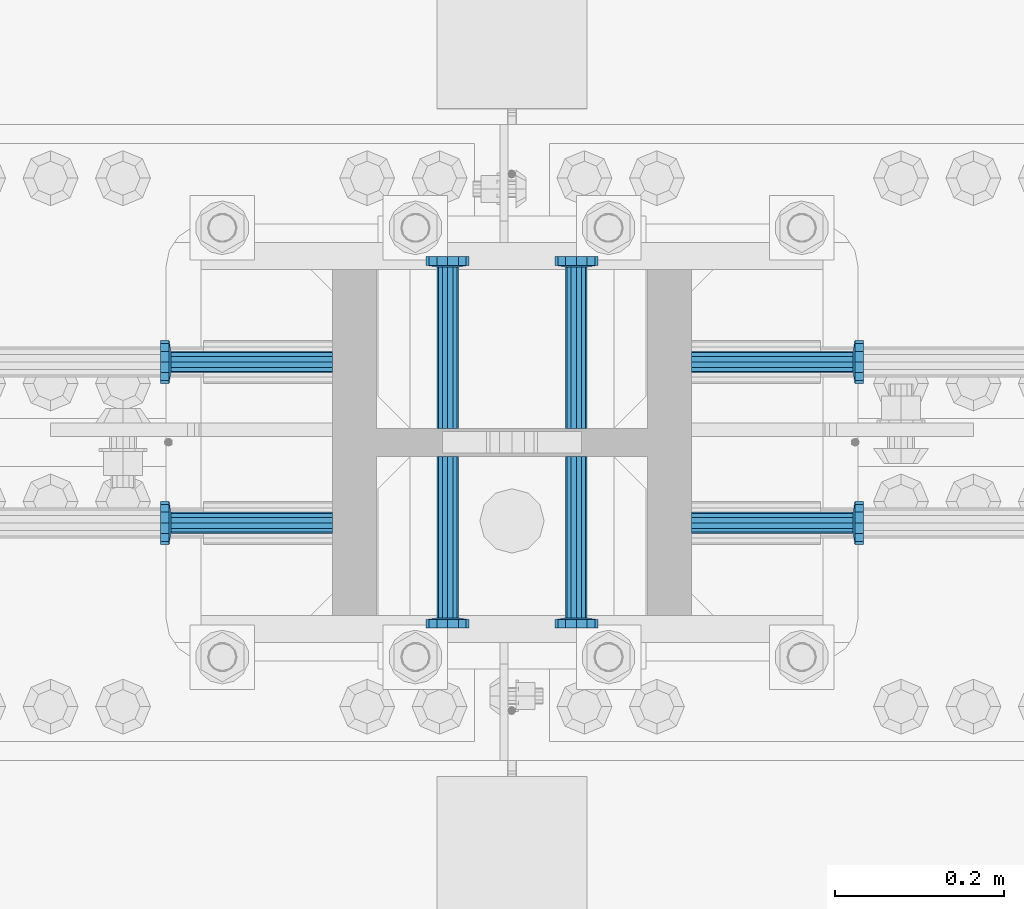
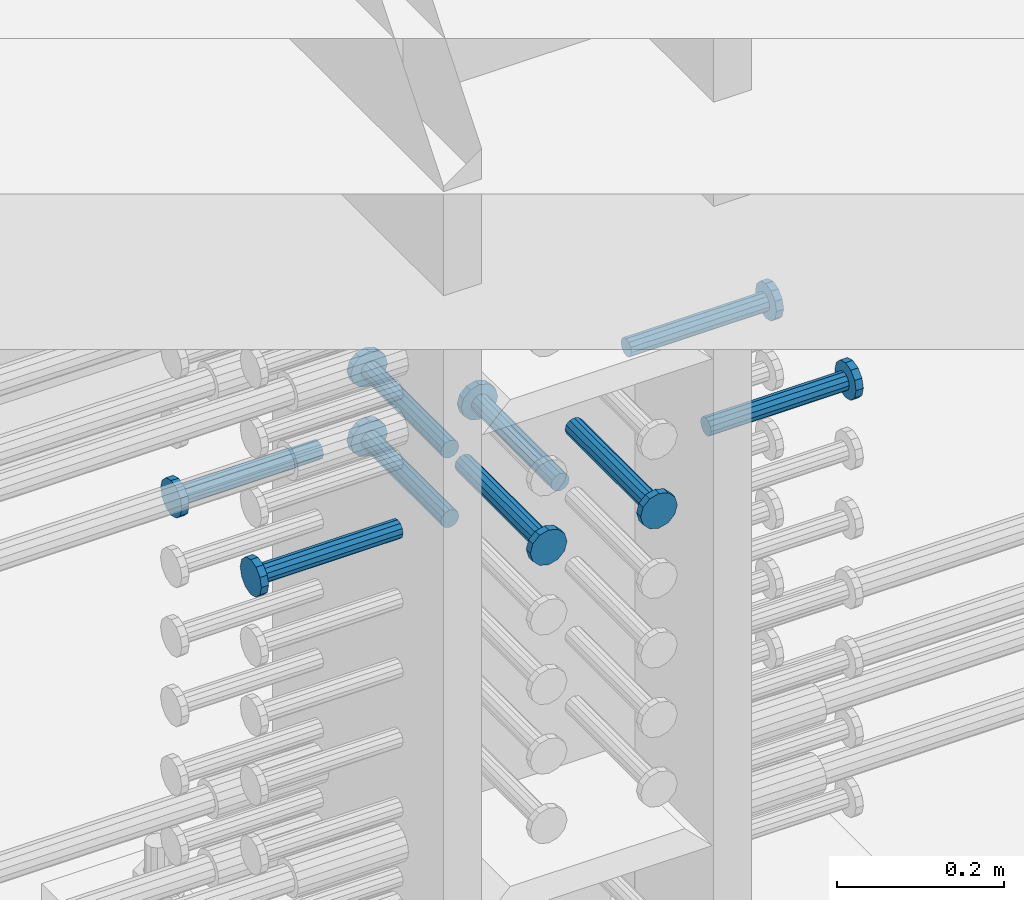
# One storey, part 1218 of 1763: 9 beams, 1 element without a shape of its own.
"""IFC2X3 building model written with IfcOpenShell, lengths in millimetres."""

from ifc_helpers import new_model, si_unit, frame, origin_with_axes, place, context, subcontext, project, spatial, faceted_brep, material, type_object, element, aggregate, save


model = new_model("IFC2X3")

# Units and contexts
model_context = context("Model", 3, precision=1e-05, world=origin_with_axes())
body_context = subcontext(model_context, "Body", "Model", "MODEL_VIEW")
ifc_project = project(units=[si_unit("LENGTHUNIT", "METRE", prefix="MILLI"), si_unit("AREAUNIT", "SQUARE_METRE"), si_unit("VOLUMEUNIT", "CUBIC_METRE"), si_unit("MASSUNIT", "GRAM", prefix="KILO"), si_unit("TIMEUNIT", "SECOND"), si_unit("PLANEANGLEUNIT", "RADIAN"), si_unit("SOLIDANGLEUNIT", "STERADIAN"), si_unit("THERMODYNAMICTEMPERATUREUNIT", "DEGREE_CELSIUS"), si_unit("LUMINOUSINTENSITYUNIT", "LUMEN")], contexts=[model_context])

# Site, building, storey
site_placement = place(None, origin_with_axes())
site = spatial("IfcSite", under=ifc_project, at=site_placement, CompositionType="ELEMENT")
building_placement = place(site_placement, origin_with_axes())
building = spatial("IfcBuilding", under=site, at=building_placement, Name="Undefined", CompositionType="ELEMENT")
storey_placement = place(building_placement, origin_with_axes())
storey = spatial("IfcBuildingStorey", under=building, at=storey_placement, Name="Undefined", CompositionType="ELEMENT", Elevation=0.0)

# Assembly, beams
assembly_placement = place(storey_placement, origin_with_axes())
assembly = element("IfcElementAssembly", 1, at=assembly_placement, inside=storey, Name="COLUMN", AssemblyPlace="NOTDEFINED", PredefinedType="RIGID_FRAME")
ifc_material = material(Name="STEEL/A108")
beam_type = type_object("IfcBeamType", PredefinedType="NOTDEFINED")
beam_1_placement = place(assembly_placement, frame((-61670.6373431002, 473.868999002865, 4622.80000000005), z_axis=(1.0, 0.0, 0.0), x_axis=(0.0, 1.0, 0.0)))
beam_1 = element("IfcBeam", 2, at=beam_1_placement, type_object=beam_type, material=ifc_material, Name="HEADED STUD ANCHOR", context=body_context, shape_type="Brep", body=[
    faceted_brep([(0.0, -12.6999999999971, -1.81898940354586e-12), (3.63797880709171e-12, -11.0, -6.34999990463257), (191.00799999576, -11.0, -6.34999990454889), (191.007999995752, -12.6999998092651, 8.36735125631094e-11), (7.27595761418343e-12, -6.34999990463257, -11.0), (191.00799999576, -6.34999990463257, -10.9999999999163), (3.63797880709171e-12, 0.0, -12.6999998092651), (191.00799999576, 0.0, -12.6999998091815), (7.27595761418343e-12, 6.34999990463257, -11.0), (191.00799999576, 6.34999990463257, -10.9999999999163), (3.63797880709171e-12, 11.0, -6.34999990463257), (191.00799999576, 11.0, -6.34999990454889), (0.0, 12.6999999999971, -1.81898940354586e-12), (191.007999995752, 12.6999998092651, 8.36735125631094e-11), (0.0, 11.0, 6.34999990463257), (191.007999995752, 11.0, 6.34999990471624), (-3.63797880709171e-12, 6.34999990463257, 11.0), (191.007999995749, 6.34999990463257, 11.0000000000837), (-3.63797880709171e-12, 0.0, 12.6999998092651), (191.007999995749, 0.0, 12.6999998093488), (-3.63797880709171e-12, -6.34999990463257, 11.0), (191.007999995749, -6.34999990463257, 11.0000000000837), (0.0, -11.0, 6.34999990463257), (191.007999995752, -11.0, 6.34999990471624), (193.039999995715, -22.0, -12.6999998091796), (193.039999995708, -25.3999996185303, 8.54925019666553e-11), (193.039999995719, -12.6999998092651, -21.9999999999145), (193.039999995719, 0.0, -25.3999996184448), (193.039999995719, 12.6999998092651, -21.9999999999145), (193.039999995715, 22.0, -12.6999998091796), (193.039999995708, 25.3999996185303, 8.54925019666553e-11), (193.039999995704, 22.0, 12.6999998093506), (193.039999995701, 12.6999998092651, 22.0000000000855), (193.039999995697, 0.0, 25.3999996186158), (193.039999995701, -12.6999998092651, 22.0000000000855), (193.039999995704, -22.0, 12.6999998093506), (203.199999995486, -22.0, -12.6999998091742), (203.199999995482, -25.3999996185303, 9.09494701772928e-11), (203.199999995493, -12.6999998092651, -21.9999999999091), (203.199999995493, 0.0, -25.3999996184393), (203.199999995493, 12.6999998092651, -21.9999999999091), (203.199999995486, 22.0, -12.6999998091742), (203.199999995482, 25.3999996185303, 9.09494701772928e-11), (203.199999995479, 22.0, 12.6999998093561), (203.199999995475, 12.6999998092651, 22.0000000000909), (203.199999995471, 0.0, 25.3999996186212), (203.199999995475, -12.6999998092651, 22.0000000000909), (203.199999995479, -22.0, 12.6999998093561)], [[[0, 1, 2, 3]], [[1, 4, 5, 2]], [[4, 6, 7, 5]], [[6, 8, 9, 7]], [[8, 10, 11, 9]], [[10, 12, 13, 11]], [[12, 14, 15, 13]], [[14, 16, 17, 15]], [[16, 18, 19, 17]], [[18, 20, 21, 19]], [[20, 22, 23, 21]], [[22, 0, 3, 23]], [[22, 20, 18, 16, 14, 12, 10, 8, 6, 4, 1, 0]], [[3, 2, 24, 25]], [[2, 5, 26, 24]], [[5, 7, 27, 26]], [[7, 9, 28, 27]], [[9, 11, 29, 28]], [[11, 13, 30, 29]], [[13, 15, 31, 30]], [[15, 17, 32, 31]], [[17, 19, 33, 32]], [[19, 21, 34, 33]], [[21, 23, 35, 34]], [[23, 3, 25, 35]], [[25, 24, 36, 37]], [[24, 26, 38, 36]], [[26, 27, 39, 38]], [[27, 28, 40, 39]], [[28, 29, 41, 40]], [[29, 30, 42, 41]], [[30, 31, 43, 42]], [[31, 32, 44, 43]], [[32, 33, 45, 44]], [[33, 34, 46, 45]], [[34, 35, 47, 46]], [[35, 25, 37, 47]], [[38, 39, 40, 41, 42, 43, 44, 45, 46, 47, 37, 36]]]),
])
beam_2_placement = place(assembly_placement, frame((-61807.1622049631, 552.449999999823, 4622.80000000005), z_axis=(0.0, 1.0, 0.0), x_axis=(-1.0, 0.0, 0.0)))
beam_2 = element("IfcBeam", 3, at=beam_2_placement, type_object=beam_type, material=ifc_material, Name="HEADED STUD ANCHOR", context=body_context, shape_type="Brep", body=[
    faceted_brep([(0.0, -12.6999999999971, -1.81898940354586e-12), (3.63797880709171e-12, -11.0, -6.34999990463257), (191.00799999576, -11.0, -6.34999990454889), (191.007999995752, -12.6999998092651, 8.36735125631094e-11), (7.27595761418343e-12, -6.34999990463257, -11.0), (191.00799999576, -6.34999990463257, -10.9999999999163), (3.63797880709171e-12, 0.0, -12.6999998092651), (191.00799999576, 0.0, -12.6999998091815), (7.27595761418343e-12, 6.34999990463257, -11.0), (191.00799999576, 6.34999990463257, -10.9999999999163), (3.63797880709171e-12, 11.0, -6.34999990463257), (191.00799999576, 11.0, -6.34999990454889), (0.0, 12.6999999999971, -1.81898940354586e-12), (191.007999995752, 12.6999998092651, 8.36735125631094e-11), (0.0, 11.0, 6.34999990463257), (191.007999995752, 11.0, 6.34999990471624), (-3.63797880709171e-12, 6.34999990463257, 11.0), (191.007999995749, 6.34999990463257, 11.0000000000837), (-3.63797880709171e-12, 0.0, 12.6999998092651), (191.007999995749, 0.0, 12.6999998093488), (-3.63797880709171e-12, -6.34999990463257, 11.0), (191.007999995749, -6.34999990463257, 11.0000000000837), (0.0, -11.0, 6.34999990463257), (191.007999995752, -11.0, 6.34999990471624), (193.039999995715, -22.0, -12.6999998091796), (193.039999995708, -25.3999996185303, 8.54925019666553e-11), (193.039999995719, -12.6999998092651, -21.9999999999145), (193.039999995719, 0.0, -25.3999996184448), (193.039999995719, 12.6999998092651, -21.9999999999145), (193.039999995715, 22.0, -12.6999998091796), (193.039999995708, 25.3999996185303, 8.54925019666553e-11), (193.039999995704, 22.0, 12.6999998093506), (193.039999995701, 12.6999998092651, 22.0000000000855), (193.039999995697, 0.0, 25.3999996186158), (193.039999995701, -12.6999998092651, 22.0000000000855), (193.039999995704, -22.0, 12.6999998093506), (203.199999995486, -22.0, -12.6999998091742), (203.199999995482, -25.3999996185303, 9.09494701772928e-11), (203.199999995493, -12.6999998092651, -21.9999999999091), (203.199999995493, 0.0, -25.3999996184393), (203.199999995493, 12.6999998092651, -21.9999999999091), (203.199999995486, 22.0, -12.6999998091742), (203.199999995482, 25.3999996185303, 9.09494701772928e-11), (203.199999995479, 22.0, 12.6999998093561), (203.199999995475, 12.6999998092651, 22.0000000000909), (203.199999995471, 0.0, 25.3999996186212), (203.199999995475, -12.6999998092651, 22.0000000000909), (203.199999995479, -22.0, 12.6999998093561)], [[[0, 1, 2, 3]], [[1, 4, 5, 2]], [[4, 6, 7, 5]], [[6, 8, 9, 7]], [[8, 10, 11, 9]], [[10, 12, 13, 11]], [[12, 14, 15, 13]], [[14, 16, 17, 15]], [[16, 18, 19, 17]], [[18, 20, 21, 19]], [[20, 22, 23, 21]], [[22, 0, 3, 23]], [[22, 20, 18, 16, 14, 12, 10, 8, 6, 4, 1, 0]], [[3, 2, 24, 25]], [[2, 5, 26, 24]], [[5, 7, 27, 26]], [[7, 9, 28, 27]], [[9, 11, 29, 28]], [[11, 13, 30, 29]], [[13, 15, 31, 30]], [[15, 17, 32, 31]], [[17, 19, 33, 32]], [[19, 21, 34, 33]], [[21, 23, 35, 34]], [[23, 3, 25, 35]], [[25, 24, 36, 37]], [[24, 26, 38, 36]], [[26, 27, 39, 38]], [[27, 28, 40, 39]], [[28, 29, 41, 40]], [[29, 30, 42, 41]], [[30, 31, 43, 42]], [[31, 32, 44, 43]], [[32, 33, 45, 44]], [[33, 34, 46, 45]], [[34, 35, 47, 46]], [[35, 25, 37, 47]], [[38, 39, 40, 41, 42, 43, 44, 45, 46, 47, 37, 36]]]),
])
beam_3_placement = place(assembly_placement, frame((-61807.1622736986, 361.949999999998, 4622.80000000005), z_axis=(0.0, 1.0, 0.0), x_axis=(-1.0, 0.0, 0.0)))
beam_3 = element("IfcBeam", 4, at=beam_3_placement, type_object=beam_type, material=ifc_material, Name="HEADED STUD ANCHOR", context=body_context, shape_type="Brep", body=[
    faceted_brep([(0.0, -12.6999999999971, -1.81898940354586e-12), (3.63797880709171e-12, -11.0, -6.34999990463257), (191.00799999576, -11.0, -6.34999990454889), (191.007999995752, -12.6999998092651, 8.36735125631094e-11), (7.27595761418343e-12, -6.34999990463257, -11.0), (191.00799999576, -6.34999990463257, -10.9999999999163), (3.63797880709171e-12, 0.0, -12.6999998092651), (191.00799999576, 0.0, -12.6999998091815), (7.27595761418343e-12, 6.34999990463257, -11.0), (191.00799999576, 6.34999990463257, -10.9999999999163), (3.63797880709171e-12, 11.0, -6.34999990463257), (191.00799999576, 11.0, -6.34999990454889), (0.0, 12.6999999999971, -1.81898940354586e-12), (191.007999995752, 12.6999998092651, 8.36735125631094e-11), (0.0, 11.0, 6.34999990463257), (191.007999995752, 11.0, 6.34999990471624), (-3.63797880709171e-12, 6.34999990463257, 11.0), (191.007999995749, 6.34999990463257, 11.0000000000837), (-3.63797880709171e-12, 0.0, 12.6999998092651), (191.007999995749, 0.0, 12.6999998093488), (-3.63797880709171e-12, -6.34999990463257, 11.0), (191.007999995749, -6.34999990463257, 11.0000000000837), (0.0, -11.0, 6.34999990463257), (191.007999995752, -11.0, 6.34999990471624), (193.039999995715, -22.0, -12.6999998091796), (193.039999995708, -25.3999996185303, 8.54925019666553e-11), (193.039999995719, -12.6999998092651, -21.9999999999145), (193.039999995719, 0.0, -25.3999996184448), (193.039999995719, 12.6999998092651, -21.9999999999145), (193.039999995715, 22.0, -12.6999998091796), (193.039999995708, 25.3999996185303, 8.54925019666553e-11), (193.039999995704, 22.0, 12.6999998093506), (193.039999995701, 12.6999998092651, 22.0000000000855), (193.039999995697, 0.0, 25.3999996186158), (193.039999995701, -12.6999998092651, 22.0000000000855), (193.039999995704, -22.0, 12.6999998093506), (203.199999995486, -22.0, -12.6999998091742), (203.199999995482, -25.3999996185303, 9.09494701772928e-11), (203.199999995493, -12.6999998092651, -21.9999999999091), (203.199999995493, 0.0, -25.3999996184393), (203.199999995493, 12.6999998092651, -21.9999999999091), (203.199999995486, 22.0, -12.6999998091742), (203.199999995482, 25.3999996185303, 9.09494701772928e-11), (203.199999995479, 22.0, 12.6999998093561), (203.199999995475, 12.6999998092651, 22.0000000000909), (203.199999995471, 0.0, 25.3999996186212), (203.199999995475, -12.6999998092651, 22.0000000000909), (203.199999995479, -22.0, 12.6999998093561)], [[[0, 1, 2, 3]], [[1, 4, 5, 2]], [[4, 6, 7, 5]], [[6, 8, 9, 7]], [[8, 10, 11, 9]], [[10, 12, 13, 11]], [[12, 14, 15, 13]], [[14, 16, 17, 15]], [[16, 18, 19, 17]], [[18, 20, 21, 19]], [[20, 22, 23, 21]], [[22, 0, 3, 23]], [[22, 20, 18, 16, 14, 12, 10, 8, 6, 4, 1, 0]], [[3, 2, 24, 25]], [[2, 5, 26, 24]], [[5, 7, 27, 26]], [[7, 9, 28, 27]], [[9, 11, 29, 28]], [[11, 13, 30, 29]], [[13, 15, 31, 30]], [[15, 17, 32, 31]], [[17, 19, 33, 32]], [[19, 21, 34, 33]], [[21, 23, 35, 34]], [[23, 3, 25, 35]], [[25, 24, 36, 37]], [[24, 26, 38, 36]], [[26, 27, 39, 38]], [[27, 28, 40, 39]], [[28, 29, 41, 40]], [[29, 30, 42, 41]], [[30, 31, 43, 42]], [[31, 32, 44, 43]], [[32, 33, 45, 44]], [[33, 34, 46, 45]], [[34, 35, 47, 46]], [[35, 25, 37, 47]], [[38, 39, 40, 41, 42, 43, 44, 45, 46, 47, 37, 36]]]),
])
beam_4_placement = place(assembly_placement, frame((-61670.6373420916, 440.53099988573, 4622.80000000005), z_axis=(1.0, 0.0, 0.0), x_axis=(0.0, -1.0, 0.0)))
beam_4 = element("IfcBeam", 5, at=beam_4_placement, type_object=beam_type, material=ifc_material, Name="HEADED STUD ANCHOR", context=body_context, shape_type="Brep", body=[
    faceted_brep([(0.0, -12.6999999999971, -1.81898940354586e-12), (3.63797880709171e-12, -11.0, -6.34999990463257), (191.00799999576, -11.0, -6.34999990454889), (191.007999995752, -12.6999998092651, 8.36735125631094e-11), (7.27595761418343e-12, -6.34999990463257, -11.0), (191.00799999576, -6.34999990463257, -10.9999999999163), (3.63797880709171e-12, 0.0, -12.6999998092651), (191.00799999576, 0.0, -12.6999998091815), (7.27595761418343e-12, 6.34999990463257, -11.0), (191.00799999576, 6.34999990463257, -10.9999999999163), (3.63797880709171e-12, 11.0, -6.34999990463257), (191.00799999576, 11.0, -6.34999990454889), (0.0, 12.6999999999971, -1.81898940354586e-12), (191.007999995752, 12.6999998092651, 8.36735125631094e-11), (0.0, 11.0, 6.34999990463257), (191.007999995752, 11.0, 6.34999990471624), (-3.63797880709171e-12, 6.34999990463257, 11.0), (191.007999995749, 6.34999990463257, 11.0000000000837), (-3.63797880709171e-12, 0.0, 12.6999998092651), (191.007999995749, 0.0, 12.6999998093488), (-3.63797880709171e-12, -6.34999990463257, 11.0), (191.007999995749, -6.34999990463257, 11.0000000000837), (0.0, -11.0, 6.34999990463257), (191.007999995752, -11.0, 6.34999990471624), (193.039999995715, -22.0, -12.6999998091796), (193.039999995708, -25.3999996185303, 8.54925019666553e-11), (193.039999995719, -12.6999998092651, -21.9999999999145), (193.039999995719, 0.0, -25.3999996184448), (193.039999995719, 12.6999998092651, -21.9999999999145), (193.039999995715, 22.0, -12.6999998091796), (193.039999995708, 25.3999996185303, 8.54925019666553e-11), (193.039999995704, 22.0, 12.6999998093506), (193.039999995701, 12.6999998092651, 22.0000000000855), (193.039999995697, 0.0, 25.3999996186158), (193.039999995701, -12.6999998092651, 22.0000000000855), (193.039999995704, -22.0, 12.6999998093506), (203.199999995486, -22.0, -12.6999998091742), (203.199999995482, -25.3999996185303, 9.09494701772928e-11), (203.199999995493, -12.6999998092651, -21.9999999999091), (203.199999995493, 0.0, -25.3999996184393), (203.199999995493, 12.6999998092651, -21.9999999999091), (203.199999995486, 22.0, -12.6999998091742), (203.199999995482, 25.3999996185303, 9.09494701772928e-11), (203.199999995479, 22.0, 12.6999998093561), (203.199999995475, 12.6999998092651, 22.0000000000909), (203.199999995471, 0.0, 25.3999996186212), (203.199999995475, -12.6999998092651, 22.0000000000909), (203.199999995479, -22.0, 12.6999998093561)], [[[0, 1, 2, 3]], [[1, 4, 5, 2]], [[4, 6, 7, 5]], [[6, 8, 9, 7]], [[8, 10, 11, 9]], [[10, 12, 13, 11]], [[12, 14, 15, 13]], [[14, 16, 17, 15]], [[16, 18, 19, 17]], [[18, 20, 21, 19]], [[20, 22, 23, 21]], [[22, 0, 3, 23]], [[22, 20, 18, 16, 14, 12, 10, 8, 6, 4, 1, 0]], [[3, 2, 24, 25]], [[2, 5, 26, 24]], [[5, 7, 27, 26]], [[7, 9, 28, 27]], [[9, 11, 29, 28]], [[11, 13, 30, 29]], [[13, 15, 31, 30]], [[15, 17, 32, 31]], [[17, 19, 33, 32]], [[19, 21, 34, 33]], [[21, 23, 35, 34]], [[23, 3, 25, 35]], [[25, 24, 36, 37]], [[24, 26, 38, 36]], [[26, 27, 39, 38]], [[27, 28, 40, 39]], [[28, 29, 41, 40]], [[29, 30, 42, 41]], [[30, 31, 43, 42]], [[31, 32, 44, 43]], [[32, 33, 45, 44]], [[33, 34, 46, 45]], [[34, 35, 47, 46]], [[35, 25, 37, 47]], [[38, 39, 40, 41, 42, 43, 44, 45, 46, 47, 37, 36]]]),
])
beam_5_placement = place(assembly_placement, frame((-61518.2373420926, 440.531000000006, 4622.80000000005), z_axis=(1.0, 0.0, 0.0), x_axis=(0.0, -1.0, 0.0)))
beam_5 = element("IfcBeam", 6, at=beam_5_placement, type_object=beam_type, material=ifc_material, Name="HEADED STUD ANCHOR", context=body_context, shape_type="Brep", body=[
    faceted_brep([(0.0, -12.6999999999971, -1.81898940354586e-12), (3.63797880709171e-12, -11.0, -6.34999990463257), (191.00799999576, -11.0, -6.34999990454889), (191.007999995752, -12.6999998092651, 8.36735125631094e-11), (7.27595761418343e-12, -6.34999990463257, -11.0), (191.00799999576, -6.34999990463257, -10.9999999999163), (3.63797880709171e-12, 0.0, -12.6999998092651), (191.00799999576, 0.0, -12.6999998091815), (7.27595761418343e-12, 6.34999990463257, -11.0), (191.00799999576, 6.34999990463257, -10.9999999999163), (3.63797880709171e-12, 11.0, -6.34999990463257), (191.00799999576, 11.0, -6.34999990454889), (0.0, 12.6999999999971, -1.81898940354586e-12), (191.007999995752, 12.6999998092651, 8.36735125631094e-11), (0.0, 11.0, 6.34999990463257), (191.007999995752, 11.0, 6.34999990471624), (-3.63797880709171e-12, 6.34999990463257, 11.0), (191.007999995749, 6.34999990463257, 11.0000000000837), (-3.63797880709171e-12, 0.0, 12.6999998092651), (191.007999995749, 0.0, 12.6999998093488), (-3.63797880709171e-12, -6.34999990463257, 11.0), (191.007999995749, -6.34999990463257, 11.0000000000837), (0.0, -11.0, 6.34999990463257), (191.007999995752, -11.0, 6.34999990471624), (193.039999995715, -22.0, -12.6999998091796), (193.039999995708, -25.3999996185303, 8.54925019666553e-11), (193.039999995719, -12.6999998092651, -21.9999999999145), (193.039999995719, 0.0, -25.3999996184448), (193.039999995719, 12.6999998092651, -21.9999999999145), (193.039999995715, 22.0, -12.6999998091796), (193.039999995708, 25.3999996185303, 8.54925019666553e-11), (193.039999995704, 22.0, 12.6999998093506), (193.039999995701, 12.6999998092651, 22.0000000000855), (193.039999995697, 0.0, 25.3999996186158), (193.039999995701, -12.6999998092651, 22.0000000000855), (193.039999995704, -22.0, 12.6999998093506), (203.199999995486, -22.0, -12.6999998091742), (203.199999995482, -25.3999996185303, 9.09494701772928e-11), (203.199999995493, -12.6999998092651, -21.9999999999091), (203.199999995493, 0.0, -25.3999996184393), (203.199999995493, 12.6999998092651, -21.9999999999091), (203.199999995486, 22.0, -12.6999998091742), (203.199999995482, 25.3999996185303, 9.09494701772928e-11), (203.199999995479, 22.0, 12.6999998093561), (203.199999995475, 12.6999998092651, 22.0000000000909), (203.199999995471, 0.0, 25.3999996186212), (203.199999995475, -12.6999998092651, 22.0000000000909), (203.199999995479, -22.0, 12.6999998093561)], [[[0, 1, 2, 3]], [[1, 4, 5, 2]], [[4, 6, 7, 5]], [[6, 8, 9, 7]], [[8, 10, 11, 9]], [[10, 12, 13, 11]], [[12, 14, 15, 13]], [[14, 16, 17, 15]], [[16, 18, 19, 17]], [[18, 20, 21, 19]], [[20, 22, 23, 21]], [[22, 0, 3, 23]], [[22, 20, 18, 16, 14, 12, 10, 8, 6, 4, 1, 0]], [[3, 2, 24, 25]], [[2, 5, 26, 24]], [[5, 7, 27, 26]], [[7, 9, 28, 27]], [[9, 11, 29, 28]], [[11, 13, 30, 29]], [[13, 15, 31, 30]], [[15, 17, 32, 31]], [[17, 19, 33, 32]], [[19, 21, 34, 33]], [[21, 23, 35, 34]], [[23, 3, 25, 35]], [[25, 24, 36, 37]], [[24, 26, 38, 36]], [[26, 27, 39, 38]], [[27, 28, 40, 39]], [[28, 29, 41, 40]], [[29, 30, 42, 41]], [[30, 31, 43, 42]], [[31, 32, 44, 43]], [[32, 33, 45, 44]], [[33, 34, 46, 45]], [[34, 35, 47, 46]], [[35, 25, 37, 47]], [[38, 39, 40, 41, 42, 43, 44, 45, 46, 47, 37, 36]]]),
])
beam_6_placement = place(assembly_placement, frame((-61381.7123210203, 361.950000000609, 4622.80000000005), z_axis=(0.0, 1.0, 0.0), x_axis=(1.0, 0.0, 0.0)))
beam_6 = element("IfcBeam", 7, at=beam_6_placement, type_object=beam_type, material=ifc_material, Name="HEADED STUD ANCHOR", context=body_context, shape_type="Brep", body=[
    faceted_brep([(0.0, -12.6999999999971, -1.81898940354586e-12), (3.63797880709171e-12, -11.0, -6.34999990463257), (191.00799999576, -11.0, -6.34999990454889), (191.007999995752, -12.6999998092651, 8.36735125631094e-11), (7.27595761418343e-12, -6.34999990463257, -11.0), (191.00799999576, -6.34999990463257, -10.9999999999163), (3.63797880709171e-12, 0.0, -12.6999998092651), (191.00799999576, 0.0, -12.6999998091815), (7.27595761418343e-12, 6.34999990463257, -11.0), (191.00799999576, 6.34999990463257, -10.9999999999163), (3.63797880709171e-12, 11.0, -6.34999990463257), (191.00799999576, 11.0, -6.34999990454889), (0.0, 12.6999999999971, -1.81898940354586e-12), (191.007999995752, 12.6999998092651, 8.36735125631094e-11), (0.0, 11.0, 6.34999990463257), (191.007999995752, 11.0, 6.34999990471624), (-3.63797880709171e-12, 6.34999990463257, 11.0), (191.007999995749, 6.34999990463257, 11.0000000000837), (-3.63797880709171e-12, 0.0, 12.6999998092651), (191.007999995749, 0.0, 12.6999998093488), (-3.63797880709171e-12, -6.34999990463257, 11.0), (191.007999995749, -6.34999990463257, 11.0000000000837), (0.0, -11.0, 6.34999990463257), (191.007999995752, -11.0, 6.34999990471624), (193.039999995715, -22.0, -12.6999998091796), (193.039999995708, -25.3999996185303, 8.54925019666553e-11), (193.039999995719, -12.6999998092651, -21.9999999999145), (193.039999995719, 0.0, -25.3999996184448), (193.039999995719, 12.6999998092651, -21.9999999999145), (193.039999995715, 22.0, -12.6999998091796), (193.039999995708, 25.3999996185303, 8.54925019666553e-11), (193.039999995704, 22.0, 12.6999998093506), (193.039999995701, 12.6999998092651, 22.0000000000855), (193.039999995697, 0.0, 25.3999996186158), (193.039999995701, -12.6999998092651, 22.0000000000855), (193.039999995704, -22.0, 12.6999998093506), (203.199999995486, -22.0, -12.6999998091742), (203.199999995482, -25.3999996185303, 9.09494701772928e-11), (203.199999995493, -12.6999998092651, -21.9999999999091), (203.199999995493, 0.0, -25.3999996184393), (203.199999995493, 12.6999998092651, -21.9999999999091), (203.199999995486, 22.0, -12.6999998091742), (203.199999995482, 25.3999996185303, 9.09494701772928e-11), (203.199999995479, 22.0, 12.6999998093561), (203.199999995475, 12.6999998092651, 22.0000000000909), (203.199999995471, 0.0, 25.3999996186212), (203.199999995475, -12.6999998092651, 22.0000000000909), (203.199999995479, -22.0, 12.6999998093561)], [[[0, 1, 2, 3]], [[1, 4, 5, 2]], [[4, 6, 7, 5]], [[6, 8, 9, 7]], [[8, 10, 11, 9]], [[10, 12, 13, 11]], [[12, 14, 15, 13]], [[14, 16, 17, 15]], [[16, 18, 19, 17]], [[18, 20, 21, 19]], [[20, 22, 23, 21]], [[22, 0, 3, 23]], [[22, 20, 18, 16, 14, 12, 10, 8, 6, 4, 1, 0]], [[3, 2, 24, 25]], [[2, 5, 26, 24]], [[5, 7, 27, 26]], [[7, 9, 28, 27]], [[9, 11, 29, 28]], [[11, 13, 30, 29]], [[13, 15, 31, 30]], [[15, 17, 32, 31]], [[17, 19, 33, 32]], [[19, 21, 34, 33]], [[21, 23, 35, 34]], [[23, 3, 25, 35]], [[25, 24, 36, 37]], [[24, 26, 38, 36]], [[26, 27, 39, 38]], [[27, 28, 40, 39]], [[28, 29, 41, 40]], [[29, 30, 42, 41]], [[30, 31, 43, 42]], [[31, 32, 44, 43]], [[32, 33, 45, 44]], [[33, 34, 46, 45]], [[34, 35, 47, 46]], [[35, 25, 37, 47]], [[38, 39, 40, 41, 42, 43, 44, 45, 46, 47, 37, 36]]]),
])
beam_7_placement = place(assembly_placement, frame((-61381.7122523598, 552.449999999998, 4622.80000000005), z_axis=(0.0, 1.0, 0.0), x_axis=(1.0, 0.0, 0.0)))
beam_7 = element("IfcBeam", 8, at=beam_7_placement, type_object=beam_type, material=ifc_material, Name="HEADED STUD ANCHOR", context=body_context, shape_type="Brep", body=[
    faceted_brep([(0.0, -12.6999999999971, -1.81898940354586e-12), (3.63797880709171e-12, -11.0, -6.34999990463257), (191.00799999576, -11.0, -6.34999990454889), (191.007999995752, -12.6999998092651, 8.36735125631094e-11), (7.27595761418343e-12, -6.34999990463257, -11.0), (191.00799999576, -6.34999990463257, -10.9999999999163), (3.63797880709171e-12, 0.0, -12.6999998092651), (191.00799999576, 0.0, -12.6999998091815), (7.27595761418343e-12, 6.34999990463257, -11.0), (191.00799999576, 6.34999990463257, -10.9999999999163), (3.63797880709171e-12, 11.0, -6.34999990463257), (191.00799999576, 11.0, -6.34999990454889), (0.0, 12.6999999999971, -1.81898940354586e-12), (191.007999995752, 12.6999998092651, 8.36735125631094e-11), (0.0, 11.0, 6.34999990463257), (191.007999995752, 11.0, 6.34999990471624), (-3.63797880709171e-12, 6.34999990463257, 11.0), (191.007999995749, 6.34999990463257, 11.0000000000837), (-3.63797880709171e-12, 0.0, 12.6999998092651), (191.007999995749, 0.0, 12.6999998093488), (-3.63797880709171e-12, -6.34999990463257, 11.0), (191.007999995749, -6.34999990463257, 11.0000000000837), (0.0, -11.0, 6.34999990463257), (191.007999995752, -11.0, 6.34999990471624), (193.039999995715, -22.0, -12.6999998091796), (193.039999995708, -25.3999996185303, 8.54925019666553e-11), (193.039999995719, -12.6999998092651, -21.9999999999145), (193.039999995719, 0.0, -25.3999996184448), (193.039999995719, 12.6999998092651, -21.9999999999145), (193.039999995715, 22.0, -12.6999998091796), (193.039999995708, 25.3999996185303, 8.54925019666553e-11), (193.039999995704, 22.0, 12.6999998093506), (193.039999995701, 12.6999998092651, 22.0000000000855), (193.039999995697, 0.0, 25.3999996186158), (193.039999995701, -12.6999998092651, 22.0000000000855), (193.039999995704, -22.0, 12.6999998093506), (203.199999995486, -22.0, -12.6999998091742), (203.199999995482, -25.3999996185303, 9.09494701772928e-11), (203.199999995493, -12.6999998092651, -21.9999999999091), (203.199999995493, 0.0, -25.3999996184393), (203.199999995493, 12.6999998092651, -21.9999999999091), (203.199999995486, 22.0, -12.6999998091742), (203.199999995482, 25.3999996185303, 9.09494701772928e-11), (203.199999995479, 22.0, 12.6999998093561), (203.199999995475, 12.6999998092651, 22.0000000000909), (203.199999995471, 0.0, 25.3999996186212), (203.199999995475, -12.6999998092651, 22.0000000000909), (203.199999995479, -22.0, 12.6999998093561)], [[[0, 1, 2, 3]], [[1, 4, 5, 2]], [[4, 6, 7, 5]], [[6, 8, 9, 7]], [[8, 10, 11, 9]], [[10, 12, 13, 11]], [[12, 14, 15, 13]], [[14, 16, 17, 15]], [[16, 18, 19, 17]], [[18, 20, 21, 19]], [[20, 22, 23, 21]], [[22, 0, 3, 23]], [[22, 20, 18, 16, 14, 12, 10, 8, 6, 4, 1, 0]], [[3, 2, 24, 25]], [[2, 5, 26, 24]], [[5, 7, 27, 26]], [[7, 9, 28, 27]], [[9, 11, 29, 28]], [[11, 13, 30, 29]], [[13, 15, 31, 30]], [[15, 17, 32, 31]], [[17, 19, 33, 32]], [[19, 21, 34, 33]], [[21, 23, 35, 34]], [[23, 3, 25, 35]], [[25, 24, 36, 37]], [[24, 26, 38, 36]], [[26, 27, 39, 38]], [[27, 28, 40, 39]], [[28, 29, 41, 40]], [[29, 30, 42, 41]], [[30, 31, 43, 42]], [[31, 32, 44, 43]], [[32, 33, 45, 44]], [[33, 34, 46, 45]], [[34, 35, 47, 46]], [[35, 25, 37, 47]], [[38, 39, 40, 41, 42, 43, 44, 45, 46, 47, 37, 36]]]),
])
beam_8_placement = place(assembly_placement, frame((-61518.2373431004, 473.869000000006, 4521.20000000005), z_axis=(1.0, 0.0, 0.0), x_axis=(0.0, 1.0, 0.0)))
beam_8 = element("IfcBeam", 9, at=beam_8_placement, type_object=beam_type, material=ifc_material, Name="HEADED STUD ANCHOR", context=body_context, shape_type="Brep", body=[
    faceted_brep([(0.0, -12.6999999999971, -1.81898940354586e-12), (3.63797880709171e-12, -11.0, -6.34999990463257), (191.00799999576, -11.0, -6.34999990454889), (191.007999995752, -12.6999998092651, 8.36735125631094e-11), (7.27595761418343e-12, -6.34999990463257, -11.0), (191.00799999576, -6.34999990463257, -10.9999999999163), (3.63797880709171e-12, 0.0, -12.6999998092651), (191.00799999576, 0.0, -12.6999998091815), (7.27595761418343e-12, 6.34999990463257, -11.0), (191.00799999576, 6.34999990463257, -10.9999999999163), (3.63797880709171e-12, 11.0, -6.34999990463257), (191.00799999576, 11.0, -6.34999990454889), (0.0, 12.6999999999971, -1.81898940354586e-12), (191.007999995752, 12.6999998092651, 8.36735125631094e-11), (0.0, 11.0, 6.34999990463257), (191.007999995752, 11.0, 6.34999990471624), (-3.63797880709171e-12, 6.34999990463257, 11.0), (191.007999995749, 6.34999990463257, 11.0000000000837), (-3.63797880709171e-12, 0.0, 12.6999998092651), (191.007999995749, 0.0, 12.6999998093488), (-3.63797880709171e-12, -6.34999990463257, 11.0), (191.007999995749, -6.34999990463257, 11.0000000000837), (0.0, -11.0, 6.34999990463257), (191.007999995752, -11.0, 6.34999990471624), (193.039999995715, -22.0, -12.6999998091796), (193.039999995708, -25.3999996185303, 8.54925019666553e-11), (193.039999995719, -12.6999998092651, -21.9999999999145), (193.039999995719, 0.0, -25.3999996184448), (193.039999995719, 12.6999998092651, -21.9999999999145), (193.039999995715, 22.0, -12.6999998091796), (193.039999995708, 25.3999996185303, 8.54925019666553e-11), (193.039999995704, 22.0, 12.6999998093506), (193.039999995701, 12.6999998092651, 22.0000000000855), (193.039999995697, 0.0, 25.3999996186158), (193.039999995701, -12.6999998092651, 22.0000000000855), (193.039999995704, -22.0, 12.6999998093506), (203.199999995486, -22.0, -12.6999998091742), (203.199999995482, -25.3999996185303, 9.09494701772928e-11), (203.199999995493, -12.6999998092651, -21.9999999999091), (203.199999995493, 0.0, -25.3999996184393), (203.199999995493, 12.6999998092651, -21.9999999999091), (203.199999995486, 22.0, -12.6999998091742), (203.199999995482, 25.3999996185303, 9.09494701772928e-11), (203.199999995479, 22.0, 12.6999998093561), (203.199999995475, 12.6999998092651, 22.0000000000909), (203.199999995471, 0.0, 25.3999996186212), (203.199999995475, -12.6999998092651, 22.0000000000909), (203.199999995479, -22.0, 12.6999998093561)], [[[0, 1, 2, 3]], [[1, 4, 5, 2]], [[4, 6, 7, 5]], [[6, 8, 9, 7]], [[8, 10, 11, 9]], [[10, 12, 13, 11]], [[12, 14, 15, 13]], [[14, 16, 17, 15]], [[16, 18, 19, 17]], [[18, 20, 21, 19]], [[20, 22, 23, 21]], [[22, 0, 3, 23]], [[22, 20, 18, 16, 14, 12, 10, 8, 6, 4, 1, 0]], [[3, 2, 24, 25]], [[2, 5, 26, 24]], [[5, 7, 27, 26]], [[7, 9, 28, 27]], [[9, 11, 29, 28]], [[11, 13, 30, 29]], [[13, 15, 31, 30]], [[15, 17, 32, 31]], [[17, 19, 33, 32]], [[19, 21, 34, 33]], [[21, 23, 35, 34]], [[23, 3, 25, 35]], [[25, 24, 36, 37]], [[24, 26, 38, 36]], [[26, 27, 39, 38]], [[27, 28, 40, 39]], [[28, 29, 41, 40]], [[29, 30, 42, 41]], [[30, 31, 43, 42]], [[31, 32, 44, 43]], [[32, 33, 45, 44]], [[33, 34, 46, 45]], [[34, 35, 47, 46]], [[35, 25, 37, 47]], [[38, 39, 40, 41, 42, 43, 44, 45, 46, 47, 37, 36]]]),
])
beam_9_placement = place(assembly_placement, frame((-61670.6373431002, 473.868999002865, 4521.20000000005), z_axis=(1.0, 0.0, 0.0), x_axis=(0.0, 1.0, 0.0)))
beam_9 = element("IfcBeam", 10, at=beam_9_placement, type_object=beam_type, material=ifc_material, Name="HEADED STUD ANCHOR", context=body_context, shape_type="Brep", body=[
    faceted_brep([(0.0, -12.6999999999971, -1.81898940354586e-12), (3.63797880709171e-12, -11.0, -6.34999990463257), (191.00799999576, -11.0, -6.34999990454889), (191.007999995752, -12.6999998092651, 8.36735125631094e-11), (7.27595761418343e-12, -6.34999990463257, -11.0), (191.00799999576, -6.34999990463257, -10.9999999999163), (3.63797880709171e-12, 0.0, -12.6999998092651), (191.00799999576, 0.0, -12.6999998091815), (7.27595761418343e-12, 6.34999990463257, -11.0), (191.00799999576, 6.34999990463257, -10.9999999999163), (3.63797880709171e-12, 11.0, -6.34999990463257), (191.00799999576, 11.0, -6.34999990454889), (0.0, 12.6999999999971, -1.81898940354586e-12), (191.007999995752, 12.6999998092651, 8.36735125631094e-11), (0.0, 11.0, 6.34999990463257), (191.007999995752, 11.0, 6.34999990471624), (-3.63797880709171e-12, 6.34999990463257, 11.0), (191.007999995749, 6.34999990463257, 11.0000000000837), (-3.63797880709171e-12, 0.0, 12.6999998092651), (191.007999995749, 0.0, 12.6999998093488), (-3.63797880709171e-12, -6.34999990463257, 11.0), (191.007999995749, -6.34999990463257, 11.0000000000837), (0.0, -11.0, 6.34999990463257), (191.007999995752, -11.0, 6.34999990471624), (193.039999995715, -22.0, -12.6999998091796), (193.039999995708, -25.3999996185303, 8.54925019666553e-11), (193.039999995719, -12.6999998092651, -21.9999999999145), (193.039999995719, 0.0, -25.3999996184448), (193.039999995719, 12.6999998092651, -21.9999999999145), (193.039999995715, 22.0, -12.6999998091796), (193.039999995708, 25.3999996185303, 8.54925019666553e-11), (193.039999995704, 22.0, 12.6999998093506), (193.039999995701, 12.6999998092651, 22.0000000000855), (193.039999995697, 0.0, 25.3999996186158), (193.039999995701, -12.6999998092651, 22.0000000000855), (193.039999995704, -22.0, 12.6999998093506), (203.199999995486, -22.0, -12.6999998091742), (203.199999995482, -25.3999996185303, 9.09494701772928e-11), (203.199999995493, -12.6999998092651, -21.9999999999091), (203.199999995493, 0.0, -25.3999996184393), (203.199999995493, 12.6999998092651, -21.9999999999091), (203.199999995486, 22.0, -12.6999998091742), (203.199999995482, 25.3999996185303, 9.09494701772928e-11), (203.199999995479, 22.0, 12.6999998093561), (203.199999995475, 12.6999998092651, 22.0000000000909), (203.199999995471, 0.0, 25.3999996186212), (203.199999995475, -12.6999998092651, 22.0000000000909), (203.199999995479, -22.0, 12.6999998093561)], [[[0, 1, 2, 3]], [[1, 4, 5, 2]], [[4, 6, 7, 5]], [[6, 8, 9, 7]], [[8, 10, 11, 9]], [[10, 12, 13, 11]], [[12, 14, 15, 13]], [[14, 16, 17, 15]], [[16, 18, 19, 17]], [[18, 20, 21, 19]], [[20, 22, 23, 21]], [[22, 0, 3, 23]], [[22, 20, 18, 16, 14, 12, 10, 8, 6, 4, 1, 0]], [[3, 2, 24, 25]], [[2, 5, 26, 24]], [[5, 7, 27, 26]], [[7, 9, 28, 27]], [[9, 11, 29, 28]], [[11, 13, 30, 29]], [[13, 15, 31, 30]], [[15, 17, 32, 31]], [[17, 19, 33, 32]], [[19, 21, 34, 33]], [[21, 23, 35, 34]], [[23, 3, 25, 35]], [[25, 24, 36, 37]], [[24, 26, 38, 36]], [[26, 27, 39, 38]], [[27, 28, 40, 39]], [[28, 29, 41, 40]], [[29, 30, 42, 41]], [[30, 31, 43, 42]], [[31, 32, 44, 43]], [[32, 33, 45, 44]], [[33, 34, 46, 45]], [[34, 35, 47, 46]], [[35, 25, 37, 47]], [[38, 39, 40, 41, 42, 43, 44, 45, 46, 47, 37, 36]]]),
])
aggregate(assembly, [beam_1, beam_2, beam_3, beam_4, beam_5, beam_6, beam_7, beam_8, beam_9])

save(model, "model.ifc")
